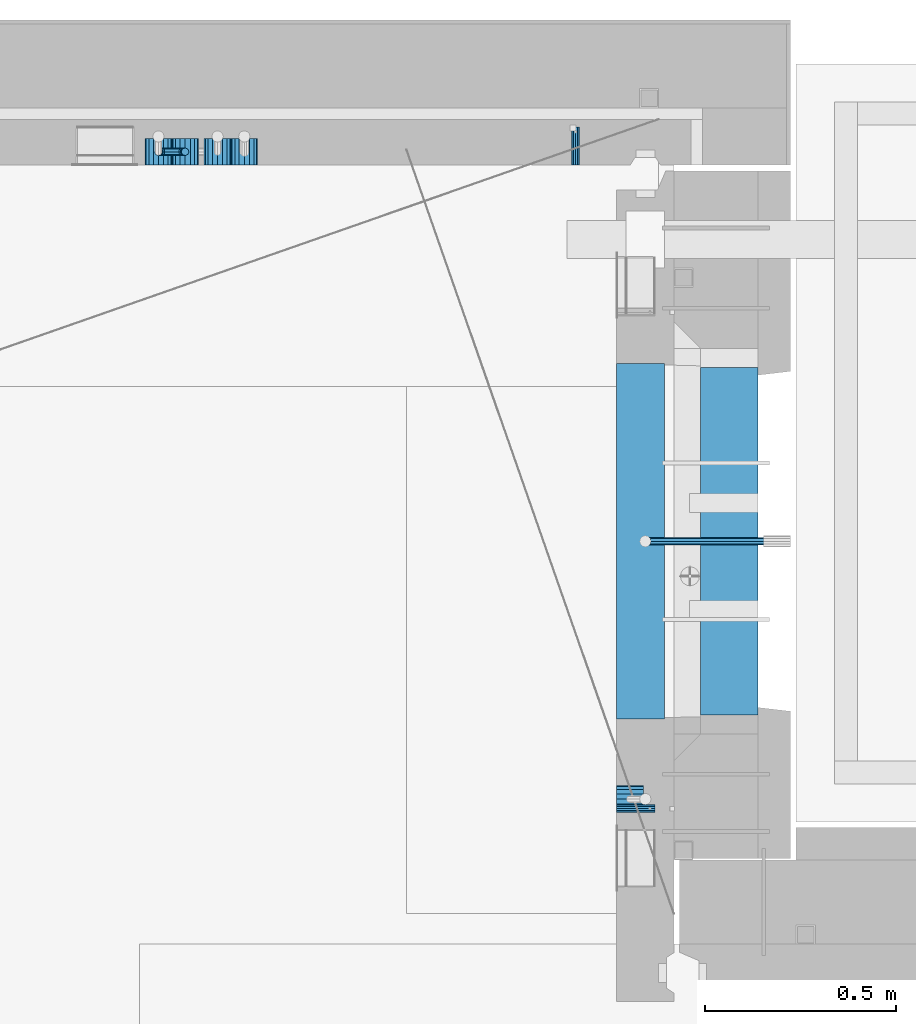
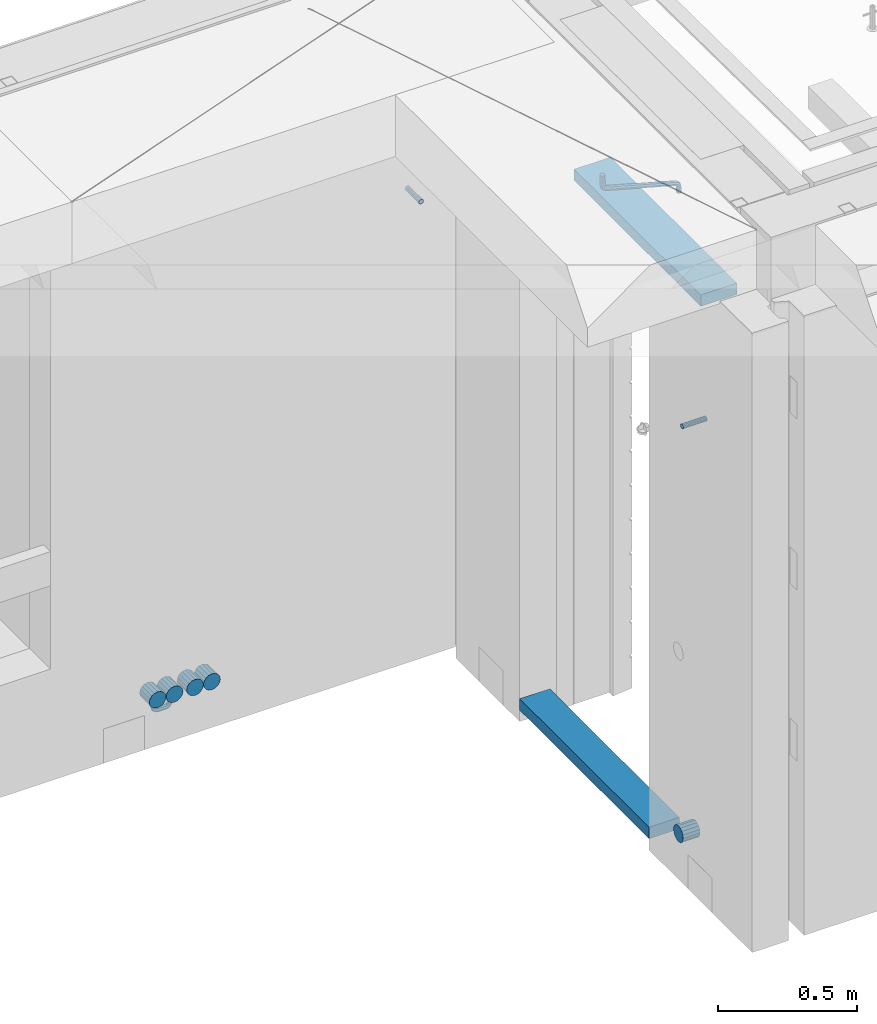
# One storey, part 166 of 352: 11 beams, 4 elements without a shape of their own.
"""IFC2X3 building model written with IfcOpenShell, lengths in millimetres."""

from ifc_helpers import new_model, si_unit, frame, origin_with_axes, place, context, subcontext, project, spatial, faceted_brep, material, type_object, element, aggregate, save


model = new_model("IFC2X3")

# Units and contexts
model_context = context("Model", 3, precision=1e-05, world=origin_with_axes())
body_context = subcontext(model_context, "Body", "Model", "MODEL_VIEW")
ifc_project = project(units=[si_unit("LENGTHUNIT", "METRE", prefix="MILLI"), si_unit("AREAUNIT", "SQUARE_METRE"), si_unit("VOLUMEUNIT", "CUBIC_METRE"), si_unit("MASSUNIT", "GRAM", prefix="KILO"), si_unit("TIMEUNIT", "SECOND"), si_unit("PLANEANGLEUNIT", "RADIAN"), si_unit("SOLIDANGLEUNIT", "STERADIAN"), si_unit("THERMODYNAMICTEMPERATUREUNIT", "DEGREE_CELSIUS"), si_unit("LUMINOUSINTENSITYUNIT", "LUMEN")], contexts=[model_context])

# Site, building, storey
site_placement = place(None, origin_with_axes())
site = spatial("IfcSite", under=ifc_project, at=site_placement, CompositionType="ELEMENT")
building_placement = place(site_placement, origin_with_axes())
building = spatial("IfcBuilding", under=site, at=building_placement, CompositionType="ELEMENT")
storey_placement = place(building_placement, origin_with_axes())
storey = spatial("IfcBuildingStorey", under=building, at=storey_placement, Name="6", CompositionType="ELEMENT", Elevation=0.0)

# Assembly, beam
assembly_1_placement = place(storey_placement, origin_with_axes())
assembly_1 = element("IfcElementAssembly", 1, at=assembly_1_placement, inside=storey, AssemblyPlace="NOTDEFINED", PredefinedType="REINFORCEMENT_UNIT")
ifc_material_1 = material(Name="TIMBER")
beam_type_1 = type_object("IfcBeamType", Name="50X150", PredefinedType="NOTDEFINED")
beam_1_placement = place(assembly_1_placement, frame((31604.9951872276, 21180.0002716511, 99080.0), z_axis=(0.0, 0.0, -1.0), x_axis=(0.0, 1.0, 0.0)))
beam_1 = element("IfcBeam", 2, at=beam_1_placement, type_object=beam_type_1, material=ifc_material_1, ObjectType="50X150", context=body_context, shape_type="Brep", body=[
    faceted_brep([(0.0, 75.0, -25.0), (1.81898940354586e-12, 75.0, 25.0), (909.999618530273, 75.0, 25.0), (909.999618530273, 75.0, -25.0), (1.81898940354586e-12, -75.0000000000009, 25.0), (909.999618530273, -75.0, 25.0), (0.0, -75.0, -25.0), (909.999618530273, -75.0, -25.0)], [[[0, 1, 2, 3]], [[1, 4, 5, 2]], [[4, 6, 7, 5]], [[6, 0, 3, 7]], [[5, 7, 3, 2]], [[6, 4, 1, 0]]]),
])

# Assemblies, beam
assembly_2_placement = place(storey_placement, origin_with_axes())
assembly_2 = element("IfcElementAssembly", 3, at=assembly_2_placement, inside=storey, AssemblyPlace="NOTDEFINED", PredefinedType="REINFORCEMENT_UNIT")
assembly_3_placement = place(assembly_2_placement, origin_with_axes())
assembly_3 = element("IfcElementAssembly", 4, at=assembly_3_placement, Name="Steel Assembly", AssemblyPlace="NOTDEFINED", PredefinedType="RIGID_FRAME")
ifc_material_2 = material(Name="STEEL/Steel_Undefined")
beam_type_2 = type_object("IfcBeamType", PredefinedType="NOTDEFINED")
beam_2_placement = place(assembly_3_placement, frame((31202.4996121022, 22620.0, 98755.0), z_axis=(1.0, 0.0, 0.0), x_axis=(0.0, 1.0, 0.0)))
beam_2 = element("IfcBeam", 5, at=beam_2_placement, type_object=beam_type_2, material=ifc_material_2, Name="M16", context=body_context, shape_type="Brep", body=[
    faceted_brep([(0.0, -8.49999999999272, -1.45519152283669e-11), (0.0, -7.36121593215648, 4.24999999998545), (100.000000000262, -7.36121593215648, 4.24999999998545), (100.000000000262, -8.49999999999272, -1.45519152283669e-11), (0.0, -4.24999999998545, 7.36121593216376), (100.000000000262, -4.24999999998545, 7.36121593216376), (0.0, 1.45519152283669e-11, 8.49999999998545), (100.000000000262, 1.45519152283669e-11, 8.49999999998545), (0.0, 4.25000000001455, 7.36121593216376), (100.000000000262, 4.25000000001455, 7.36121593216376), (0.0, 7.36121593217104, 4.24999999998545), (100.000000000262, 7.36121593217104, 4.24999999998545), (0.0, 8.50000000000728, 0.0), (100.000000000262, 8.50000000000728, 0.0), (0.0, 7.36121593217104, -4.25000000001455), (100.000000000262, 7.36121593217104, -4.25000000001455), (0.0, 4.25000000000728, -7.36121593219286), (100.000000000262, 4.25000000000728, -7.36121593219286), (0.0, 7.27595761418343e-12, -8.5), (100.000000000262, 7.27595761418343e-12, -8.5), (0.0, -4.24999999999272, -7.36121593217831), (100.000000000262, -4.24999999999272, -7.36121593217831), (0.0, -7.36121593215648, -4.25), (100.000000000262, -7.36121593215648, -4.25), (0.0, -10.4999999999927, -1.45519152283669e-11), (0.0, -9.09326673972828, -5.25000000001455), (100.000000000262, -9.09326673972828, -5.25000000001455), (100.000000000262, -10.4999999999927, -1.45519152283669e-11), (0.0, -5.24999999998545, -9.09326673974283), (100.000000000262, -5.24999999998545, -9.09326673974283), (0.0, 7.27595761418343e-12, -10.5), (100.000000000262, 7.27595761418343e-12, -10.5), (0.0, 5.25000000001455, -9.09326673975738), (100.000000000262, 5.25000000001455, -9.09326673975738), (0.0, 9.09326673975011, -5.25000000001455), (100.000000000262, 9.09326673975011, -5.25000000001455), (0.0, 10.5000000000073, -1.45519152283669e-11), (100.000000000262, 10.5000000000073, -1.45519152283669e-11), (0.0, 9.09326673975011, 5.25), (100.000000000262, 9.09326673975011, 5.25), (0.0, 5.25000000000728, 9.09326673972828), (100.000000000262, 5.25000000000728, 9.09326673972828), (0.0, 1.45519152283669e-11, 10.4999999999854), (100.000000000262, 1.45519152283669e-11, 10.4999999999854), (0.0, -5.24999999999272, 9.09326673972828), (100.000000000262, -5.24999999999272, 9.09326673972828), (0.0, -9.09326673972828, 5.24999999998545), (100.000000000262, -9.09326673972828, 5.24999999998545)], [[[0, 1, 2, 3]], [[1, 4, 5, 2]], [[4, 6, 7, 5]], [[6, 8, 9, 7]], [[8, 10, 11, 9]], [[10, 12, 13, 11]], [[12, 14, 15, 13]], [[14, 16, 17, 15]], [[16, 18, 19, 17]], [[18, 20, 21, 19]], [[20, 22, 23, 21]], [[22, 0, 3, 23]], [[24, 25, 26, 27]], [[25, 28, 29, 26]], [[28, 30, 31, 29]], [[30, 32, 33, 31]], [[32, 34, 35, 33]], [[34, 36, 37, 35]], [[36, 38, 39, 37]], [[38, 40, 41, 39]], [[40, 42, 43, 41]], [[42, 44, 45, 43]], [[44, 46, 47, 45]], [[46, 24, 27, 47]], [[29, 31, 33, 35, 37, 39, 41, 43, 45, 47, 27, 26], [5, 7, 9, 11, 13, 15, 17, 19, 21, 23, 3, 2]], [[46, 44, 42, 40, 38, 36, 34, 32, 30, 28, 25, 24], [22, 20, 18, 16, 14, 12, 10, 8, 6, 4, 1, 0]]]),
])
aggregate(assembly_3, [beam_2])

# Assembly, beam
assembly_4_placement = place(assembly_1_placement, origin_with_axes())
assembly_4 = element("IfcElementAssembly", 6, at=assembly_4_placement, Name="Steel Assembly", AssemblyPlace="NOTDEFINED", PredefinedType="RIGID_FRAME")
beam_3_placement = place(assembly_4_placement, frame((31309.9951872276, 20934.9968878339, 98755.0), z_axis=(0.0, -1.0, 0.0), x_axis=(1.0, 0.0, 0.0)))
beam_3 = element("IfcBeam", 7, at=beam_3_placement, type_object=beam_type_2, material=ifc_material_2, Name="M16", context=body_context, shape_type="Brep", body=[
    faceted_brep([(0.0, -8.49999999999272, -1.45519152283669e-11), (0.0, -7.36121593215648, 4.24999999998545), (100.000000000262, -7.36121593215648, 4.24999999998545), (100.000000000262, -8.49999999999272, -1.45519152283669e-11), (0.0, -4.24999999998545, 7.36121593216376), (100.000000000262, -4.24999999998545, 7.36121593216376), (0.0, 1.45519152283669e-11, 8.49999999998545), (100.000000000262, 1.45519152283669e-11, 8.49999999998545), (0.0, 4.25000000001455, 7.36121593216376), (100.000000000262, 4.25000000001455, 7.36121593216376), (0.0, 7.36121593217104, 4.24999999998545), (100.000000000262, 7.36121593217104, 4.24999999998545), (0.0, 8.50000000000728, 0.0), (100.000000000262, 8.50000000000728, 0.0), (0.0, 7.36121593217104, -4.25000000001455), (100.000000000262, 7.36121593217104, -4.25000000001455), (0.0, 4.25000000000728, -7.36121593219286), (100.000000000262, 4.25000000000728, -7.36121593219286), (0.0, 7.27595761418343e-12, -8.5), (100.000000000262, 7.27595761418343e-12, -8.5), (0.0, -4.24999999999272, -7.36121593217831), (100.000000000262, -4.24999999999272, -7.36121593217831), (0.0, -7.36121593215648, -4.25), (100.000000000262, -7.36121593215648, -4.25), (0.0, -10.4999999999927, -1.45519152283669e-11), (0.0, -9.09326673972828, -5.25000000001455), (100.000000000262, -9.09326673972828, -5.25000000001455), (100.000000000262, -10.4999999999927, -1.45519152283669e-11), (0.0, -5.24999999998545, -9.09326673974283), (100.000000000262, -5.24999999998545, -9.09326673974283), (0.0, 7.27595761418343e-12, -10.5), (100.000000000262, 7.27595761418343e-12, -10.5), (0.0, 5.25000000001455, -9.09326673975738), (100.000000000262, 5.25000000001455, -9.09326673975738), (0.0, 9.09326673975011, -5.25000000001455), (100.000000000262, 9.09326673975011, -5.25000000001455), (0.0, 10.5000000000073, -1.45519152283669e-11), (100.000000000262, 10.5000000000073, -1.45519152283669e-11), (0.0, 9.09326673975011, 5.25), (100.000000000262, 9.09326673975011, 5.25), (0.0, 5.25000000000728, 9.09326673972828), (100.000000000262, 5.25000000000728, 9.09326673972828), (0.0, 1.45519152283669e-11, 10.4999999999854), (100.000000000262, 1.45519152283669e-11, 10.4999999999854), (0.0, -5.24999999999272, 9.09326673972828), (100.000000000262, -5.24999999999272, 9.09326673972828), (0.0, -9.09326673972828, 5.24999999998545), (100.000000000262, -9.09326673972828, 5.24999999998545)], [[[0, 1, 2, 3]], [[1, 4, 5, 2]], [[4, 6, 7, 5]], [[6, 8, 9, 7]], [[8, 10, 11, 9]], [[10, 12, 13, 11]], [[12, 14, 15, 13]], [[14, 16, 17, 15]], [[16, 18, 19, 17]], [[18, 20, 21, 19]], [[20, 22, 23, 21]], [[22, 0, 3, 23]], [[24, 25, 26, 27]], [[25, 28, 29, 26]], [[28, 30, 31, 29]], [[30, 32, 33, 31]], [[32, 34, 35, 33]], [[34, 36, 37, 35]], [[36, 38, 39, 37]], [[38, 40, 41, 39]], [[40, 42, 43, 41]], [[42, 44, 45, 43]], [[44, 46, 47, 45]], [[46, 24, 27, 47]], [[29, 31, 33, 35, 37, 39, 41, 43, 45, 47, 27, 26], [5, 7, 9, 11, 13, 15, 17, 19, 21, 23, 3, 2]], [[46, 44, 42, 40, 38, 36, 34, 32, 30, 28, 25, 24], [22, 20, 18, 16, 14, 12, 10, 8, 6, 4, 1, 0]]]),
])
aggregate(assembly_4, [beam_3])

# Beam
ifc_material_3 = material()
beam_type_3 = type_object("IfcBeamType", Name="D20", PredefinedType="NOTDEFINED")
beam_4_placement = place(assembly_2_placement, frame((30110.0, 22655.0000005921, 96920.0), z_axis=(0.000207344999896057, 0.999999978504025, 0.0), x_axis=(0.0, 0.0, -1.0)))
beam_4 = element("IfcBeam", 8, at=beam_4_placement, type_object=beam_type_3, material=ifc_material_3, Name="JM20", ObjectType="D20", context=body_context, shape_type="Brep", body=[
    faceted_brep([(0.0, -10.0, 0.0), (-4.19531716033816e-08, -7.07106781186667, -7.07106781187031), (15.0, -7.07106781186303, -7.07106781186303), (15.0, -10.0, 0.0), (0.0, 0.0, -10.0), (15.0, 0.0, -10.0), (4.196772351861e-08, 7.07106781186303, -7.07106781186667), (15.0, 7.07106781186303, -7.07106781186303), (0.0, 10.0, 0.0), (15.0, 10.0, 0.0), (4.196772351861e-08, 7.07106781185939, 7.07106781185939), (15.0, 7.07106781186303, 7.07106781186303), (0.0, 0.0, 10.0), (15.0, 0.0, 10.0), (-4.19531716033816e-08, -7.07106781187031, 7.07106781185939), (15.0, -7.07106781186303, 7.07106781186303), (26.4805029249983, 7.71638602031089, -4.48664359282702e-05), (25.3600699192612, 5.00995527536361, -7.07100705464109), (22.6542637537787, -1.5230460533603, -9.99968429821456), (19.9481089831243, -8.05567439054357, -7.07049718768394), (18.826834370062, -10.7612046541835, 0.00067619437322719), (19.9472673757409, -8.05477390922533, 7.07163838257111), (22.6530735411652, -1.52177258047232, 10.0003156261519), (25.3592283118487, 5.01085575670004, 7.07112851561396), (34.1416172347817, -0.856916444474336, 7.07197867868672), (36.213203398147, 1.21320358659068, 0.000785173426265828), (29.141402548732, -5.85652387542723, 10.0012144823486), (24.1416172883619, -10.8569164797627, 7.07258597800683), (22.0710678501491, -12.9289320870121, 0.00164402434893418), (24.1426540134416, -10.8588120558743, -7.06954948090424), (29.1428686994623, -5.8592046249214, -9.99878528456611), (34.1426539599051, -0.858812020647747, -7.07015678022435), (40.0100668298401, -9.63902468957167, 7.07343309580028), (42.7163859636639, -8.51949674357456, 0.00228483768296428), (33.4771117462369, -12.3444560058379, 10.0025597629719), (26.9444371984719, -15.0509857193756, 7.07382216348924), (24.2387953379803, -16.1731654308933, 0.00283506249979837), (26.9451144717314, -15.0536374847834, -7.0683131956248), (33.47806955532, -12.3482061684881, -9.99743986281101), (40.0107441031432, -9.64167645503403, -7.06870226332103), (42.0710678126343, -19.9985334195844, 7.07521456002723), (45.0000000007858, -19.9999995702492, 0.00414690004981821), (35.0000000006694, -19.9979261199842, 10.0041466852272), (27.9289321887481, -19.9985334194498, 7.07521455996903), (25.0, -19.9999995700782, 0.00414690009347396), (27.928932188719, -20.0014657206229, -7.06692075997853), (35.0000000006548, -20.0020730201395, -9.99585288517846), (42.0710678125906, -20.001465720783, -7.0669207599276), (27.928932188137, -50.001465075733, -7.06070040962368), (24.9999999998254, -49.9999989249554, 0.010367250208219), (35.0, -50.0020723751913, -9.98963253479451), (42.071067811863, -50.001465075733, -7.06070040962368), (45.0, -49.999998925141, 0.0103672502445988), (42.071067811863, -49.9985327745489, 7.08143491011288), (35.0, -49.9979254750906, 10.010367035291), (27.928932188137, -49.9985327745489, 7.08143491011288), (42.7163859754073, -61.4805016490391, 0.0127476751804352), (40.0104054746334, -60.3611140008325, -7.05855238820368), (33.4775906501454, -57.6557408577646, -9.98804558495613), (26.944775825672, -54.9491531157582, -7.05967453130143), (24.2387953248981, -53.8268331663385, 0.0111607251892565), (26.9447758256429, -54.9462208145851, 7.08246078858792), (33.4775906501163, -57.6515939576748, 10.0119539853549), (40.0104054746189, -60.3581816996521, 7.08358293168567), (34.1421356237697, -69.1406679865104, 7.08540393637668), (36.213203435691, -71.213201904422, 0.014765702006116), (29.1421356236242, -64.1400607945761, 10.0132993365623), (24.1421356235078, -59.1406682015404, 7.0833304863263), (22.0710678116011, -57.071066584791, 0.011833400807518), (24.1421356235223, -59.1436005027172, -7.05880483355577), (29.1421356236242, -64.1442076946769, -9.98670023374871), (34.1421356237552, -69.1436002877017, -7.05673138350539), (25.3596491481148, -75.008937711249, 7.08662069281127), (26.4805029710988, -77.7163843043891, 0.0161141044009128), (22.6536686472245, -68.475515727856, 10.014198271514), (19.9476881463488, -61.943308343376, 7.08391159978055), (18.8268343233794, -59.2387940514018, 0.0122828682870022), (19.9476881463343, -61.94624064456, -7.05822372010152), (22.6536686471809, -68.4796626279458, -9.98580129879701), (25.3596491480712, -75.0118700124258, -7.05551462707081), (15.0000000001164, -77.0696000043099, 7.08704796086386), (15.0000000001746, -79.9999982800764, 0.0165876003811718), (14.9999999999418, -69.9979250449542, 10.0145139355009), (14.9999999997963, -62.9274646845297, 7.08411565970164), (15.0, -59.9999987101801, 0.0124407002949738), (14.9999999997672, -62.9303969856919, -7.05801966018043), (14.9999999998836, -70.0020719450404, -9.98548563481017), (15.0000000000582, -77.0725323054685, -7.05508735901822), (0.0, -62.9303969859466, -7.05801966011495), (0.0, -59.9999987101801, 0.0124407002949738), (0.0, -70.0020719452732, -9.98548563470104), (0.0, -77.0725323056759, -7.0550873589309), (0.0, -79.9999982802619, 0.0165876003884478), (0.0, -77.0696000044954, 7.08704796080565), (0.0, -69.9979250451725, 10.0145139353845), (0.0, -62.9274646847625, 7.0841156596216)], [[[0, 1, 2, 3]], [[1, 4, 5, 2]], [[4, 6, 7, 5]], [[6, 8, 9, 7]], [[8, 10, 11, 9]], [[10, 12, 13, 11]], [[12, 14, 15, 13]], [[14, 0, 3, 15]], [[14, 12, 10, 8, 6, 4, 1, 0]], [[7, 9, 16, 17]], [[5, 7, 17, 18]], [[2, 5, 18, 19]], [[3, 2, 19, 20]], [[15, 3, 20, 21]], [[13, 15, 21, 22]], [[11, 13, 22, 23]], [[9, 11, 23, 16]], [[23, 24, 25, 16]], [[22, 26, 24, 23]], [[21, 27, 26, 22]], [[20, 28, 27, 21]], [[19, 29, 28, 20]], [[18, 30, 29, 19]], [[17, 31, 30, 18]], [[16, 25, 31, 17]], [[24, 32, 33, 25]], [[26, 34, 32, 24]], [[27, 35, 34, 26]], [[28, 36, 35, 27]], [[29, 37, 36, 28]], [[30, 38, 37, 29]], [[31, 39, 38, 30]], [[25, 33, 39, 31]], [[32, 40, 41, 33]], [[34, 42, 40, 32]], [[35, 43, 42, 34]], [[36, 44, 43, 35]], [[37, 45, 44, 36]], [[38, 46, 45, 37]], [[39, 47, 46, 38]], [[33, 41, 47, 39]], [[44, 45, 48, 49]], [[45, 46, 50, 48]], [[46, 47, 51, 50]], [[47, 41, 52, 51]], [[41, 40, 53, 52]], [[40, 42, 54, 53]], [[42, 43, 55, 54]], [[43, 44, 49, 55]], [[51, 52, 56, 57]], [[50, 51, 57, 58]], [[48, 50, 58, 59]], [[49, 48, 59, 60]], [[55, 49, 60, 61]], [[54, 55, 61, 62]], [[53, 54, 62, 63]], [[52, 53, 63, 56]], [[63, 64, 65, 56]], [[62, 66, 64, 63]], [[61, 67, 66, 62]], [[60, 68, 67, 61]], [[59, 69, 68, 60]], [[58, 70, 69, 59]], [[57, 71, 70, 58]], [[56, 65, 71, 57]], [[64, 72, 73, 65]], [[66, 74, 72, 64]], [[67, 75, 74, 66]], [[68, 76, 75, 67]], [[69, 77, 76, 68]], [[70, 78, 77, 69]], [[71, 79, 78, 70]], [[65, 73, 79, 71]], [[72, 80, 81, 73]], [[74, 82, 80, 72]], [[75, 83, 82, 74]], [[76, 84, 83, 75]], [[77, 85, 84, 76]], [[78, 86, 85, 77]], [[79, 87, 86, 78]], [[73, 81, 87, 79]], [[84, 85, 88, 89]], [[85, 86, 90, 88]], [[86, 87, 91, 90]], [[87, 81, 92, 91]], [[81, 80, 93, 92]], [[80, 82, 94, 93]], [[82, 83, 95, 94]], [[83, 84, 89, 95]], [[90, 91, 92, 93, 94, 95, 89, 88]]]),
])

beam_5_placement = place(assembly_1_placement, frame((31702.0651872276, 21635.0000000039, 99220.28), z_axis=(-0.999209485784166, -0.00020572799995638, -0.0397537569914116), x_axis=(-0.0397537569985676, 6.39999925638301e-08, 0.999209506962626)))
beam_5 = element("IfcBeam", 9, at=beam_5_placement, type_object=beam_type_3, material=ifc_material_3, Name="JM20", ObjectType="D20", context=body_context, shape_type="Brep", body=[
    faceted_brep([(0.0, -10.0, 0.0), (-4.19531716033816e-08, -7.07106781186667, -7.07106781187031), (26.3851730625611, -7.07106780271351, -7.07106779974674), (26.3851730660535, -9.99999999077045, 1.18243406177498e-08), (0.0, 0.0, -10.0), (26.3851730589668, 9.14587872102857e-09, -9.99999998788189), (4.196772351861e-08, 7.07106781186303, -7.07106781186667), (26.3851730576571, 7.07106782101255, -7.0710677997472), (0.0, 10.0, 0.0), (26.3851730593888, 10.0000000091495, 1.21176526590716e-08), (4.196772351861e-08, 7.07106781185939, 7.07106781185939), (26.3851730631723, 7.07106782101619, 7.07106782398387), (0.0, 0.0, 10.0), (26.3851730667375, 9.15315467864275e-09, 10.0000000121181), (-4.19531716033816e-08, -7.07106781187031, 7.07106781185939), (26.3851730680617, -7.07106780271351, 7.07106782398296), (38.6387990555377, 0.00053833780111745, -7.38336449283906), (37.4430586178205, -7.07058200552274, -4.70977034770021), (34.5550974405633, -9.99964106806146, 1.74460312923975), (31.6666440137633, -7.07083577596131, 8.19887149183023), (30.4697151806322, 0.000179452214069897, 10.8722118684241), (31.6654556183639, 7.07129979554884, 8.19861772327886), (34.5534167956066, 10.0003588580803, 1.74424424634026), (37.4418702223775, 7.07155356597286, -4.71002411625204), (46.5698109210789, 7.07292605872499, 1.96124086770624), (48.7548734831362, 0.00205940803425619, 0.0100898832683924), (41.2967727296491, 10.0013728005906, 6.67270684289633), (36.0246331664675, 7.07195524891722, 11.3845749391899), (33.8417400848848, 0.000686475628754124, 13.3366967298962), (36.0268026468402, -7.07018017507653, 11.385545745416), (41.2998408382991, -9.99862691692761, 6.67407977023777), (46.5719804015243, -7.06920936526149, 1.96221167398289), (52.1766955363273, 7.07494587836845, 11.77897587077), (54.9687243336812, 0.00429788071051007, 10.8906314292522), (45.4389138642146, 10.0028649622, 13.9256551011317), (38.7022804405424, 7.07291984242329, 16.0731735411446), (35.9130237601494, 0.00143263318750542, 16.9635440140905), (38.7050525575032, -7.06921536447044, 16.0751995724927), (45.4428342298197, -9.99713444846202, 13.9285203429881), (52.1794676532882, -7.06718932852891, 11.7810019021831), (142.166420299589, -7.00909836739083, 294.143799597011), (135.429786872017, -9.93904348683645, 296.291318034092), (144.955676979953, 0.0623888418631395, 293.253429124143), (142.163648182657, 7.13303683951744, 294.141773565681), (135.425866510661, 10.0609559233271, 296.288452795829), (128.689233087061, 7.13101080351771, 298.435971235634), (125.899976406712, 0.0595235942673753, 299.326341708503), (128.692005203993, -7.01112440339057, 298.437997266966), (147.068569920637, 0.0631443010061048, 296.926548661886), (144.897857494318, -7.00812174957537, 298.892215917644), (139.655137467547, -9.93753272500544, 303.636800386314), (134.411524128242, -7.00907940566321, 308.380988833921), (132.238655054738, 0.0617899707685865, 310.345700010335), (134.409367481101, 7.13305602133914, 308.38003275464), (139.652087507944, 10.0624669967765, 303.63544828606), (144.895700847192, 7.13401367743427, 298.891259838389), (149.349355837621, 7.13466950711154, 302.082919188319), (150.512901837996, 0.0636515012993186, 299.394888529177), (146.541460642286, 10.0634815017911, 308.572636332), (143.734043175544, 7.13442914049301, 315.062451673432), (142.571650514263, 0.0633115715718304, 317.750719402909), (143.735196514695, -7.0077064342513, 315.062688743805), (146.543091710148, -9.93651842893087, 308.572971600169), (149.350509176773, -7.0074660676255, 302.083156258706), (154.724909358454, 7.13488656737172, 303.143653317829), (154.670204234542, 0.063819369621342, 300.215230568659), (154.856921558763, 10.0638172729959, 310.213489346082), (154.988909878753, 7.13488360238989, 317.283324591871), (155.043557350815, 0.0638151764978829, 320.211745451903), (154.988852227005, -7.00725202125614, 317.28332270274), (154.856840031658, -9.93618272723688, 310.213486674455), (154.724851706691, -7.00724905626703, 303.143651428684), (199.544700311235, -7.00743165723543, 302.30682413155), (199.676688632229, -9.93636532781238, 309.37665937721), (199.490052838737, 0.0636367686238373, 299.378403271518), (199.544757962984, 7.13470396637786, 302.306826020583), (199.676770164122, 10.0636346720203, 309.376662048705), (199.808758485131, 7.13470100144696, 316.446497294365), (199.863405957614, 0.0636325755804137, 319.374918154397), (199.808700833368, -7.00743462216269, 316.446495405334)], [[[0, 1, 2, 3]], [[1, 4, 5, 2]], [[4, 6, 7, 5]], [[6, 8, 9, 7]], [[8, 10, 11, 9]], [[10, 12, 13, 11]], [[12, 14, 15, 13]], [[14, 0, 3, 15]], [[14, 12, 10, 8, 6, 4, 1, 0]], [[2, 5, 16, 17]], [[3, 2, 17, 18]], [[15, 3, 18, 19]], [[13, 15, 19, 20]], [[11, 13, 20, 21]], [[9, 11, 21, 22]], [[7, 9, 22, 23]], [[5, 7, 23, 16]], [[23, 24, 25, 16]], [[22, 26, 24, 23]], [[21, 27, 26, 22]], [[20, 28, 27, 21]], [[19, 29, 28, 20]], [[18, 30, 29, 19]], [[17, 31, 30, 18]], [[16, 25, 31, 17]], [[24, 32, 33, 25]], [[26, 34, 32, 24]], [[27, 35, 34, 26]], [[28, 36, 35, 27]], [[29, 37, 36, 28]], [[30, 38, 37, 29]], [[31, 39, 38, 30]], [[25, 33, 39, 31]], [[38, 39, 40, 41]], [[39, 33, 42, 40]], [[33, 32, 43, 42]], [[32, 34, 44, 43]], [[34, 35, 45, 44]], [[35, 36, 46, 45]], [[36, 37, 47, 46]], [[37, 38, 41, 47]], [[40, 42, 48, 49]], [[41, 40, 49, 50]], [[47, 41, 50, 51]], [[46, 47, 51, 52]], [[45, 46, 52, 53]], [[44, 45, 53, 54]], [[43, 44, 54, 55]], [[42, 43, 55, 48]], [[55, 56, 57, 48]], [[54, 58, 56, 55]], [[53, 59, 58, 54]], [[52, 60, 59, 53]], [[51, 61, 60, 52]], [[50, 62, 61, 51]], [[49, 63, 62, 50]], [[48, 57, 63, 49]], [[56, 64, 65, 57]], [[58, 66, 64, 56]], [[59, 67, 66, 58]], [[60, 68, 67, 59]], [[61, 69, 68, 60]], [[62, 70, 69, 61]], [[63, 71, 70, 62]], [[57, 65, 71, 63]], [[70, 71, 72, 73]], [[71, 65, 74, 72]], [[65, 64, 75, 74]], [[64, 66, 76, 75]], [[66, 67, 77, 76]], [[67, 68, 78, 77]], [[68, 69, 79, 78]], [[69, 70, 73, 79]], [[74, 75, 76, 77, 78, 79, 73, 72]]]),
])

beam_type_4 = type_object("IfcBeamType", Name="D70", PredefinedType="NOTDEFINED")
beam_6_placement = place(assembly_2_placement, frame((30110.0, 22619.9999977209, 96955.0), z_axis=(0.0, 0.0, 1.0), x_axis=(0.0, 1.0, 0.0)))
beam_6 = element("IfcBeam", 10, at=beam_6_placement, type_object=beam_type_4, material=ifc_material_3, ObjectType="D70", context=body_context, shape_type="Brep", body=[
    faceted_brep([(0.0, -35.0, 0.0), (0.0, -32.3357836378964, -13.3939201327739), (70.0, -32.3357836378964, -13.3939201327739), (70.0, -35.0, 0.0), (0.0, -24.7487373415279, -24.7487373415352), (70.0, -24.7487373415279, -24.7487373415352), (0.0, -13.3939201327776, -32.3357836379), (70.0, -13.3939201327776, -32.3357836379), (0.0, 0.0, -35.0), (70.0, 0.0, -35.0), (0.0, 13.3939201327776, -32.3357836379), (70.0, 13.3939201327776, -32.3357836379), (0.0, 24.7487373415279, -24.7487373415352), (70.0, 24.7487373415279, -24.7487373415352), (0.0, 32.3357836378964, -13.3939201327739), (70.0, 32.3357836378964, -13.3939201327739), (0.0, 35.0, 0.0), (70.0, 35.0, 0.0), (0.0, 32.3357836378964, 13.3939201327739), (70.0, 32.3357836378964, 13.3939201327739), (0.0, 24.7487373415279, 24.7487373415352), (70.0, 24.7487373415279, 24.7487373415352), (0.0, 13.3939201327776, 32.3357836379), (70.0, 13.3939201327776, 32.3357836379), (0.0, 0.0, 35.0), (70.0, 0.0, 35.0), (0.0, -13.3939201327776, 32.3357836379), (70.0, -13.3939201327776, 32.3357836379), (0.0, -24.7487373415279, 24.7487373415352), (70.0, -24.7487373415279, 24.7487373415352), (0.0, -32.3357836378964, 13.3939201327739), (70.0, -32.3357836378964, 13.3939201327739)], [[[0, 1, 2, 3]], [[1, 4, 5, 2]], [[4, 6, 7, 5]], [[6, 8, 9, 7]], [[8, 10, 11, 9]], [[10, 12, 13, 11]], [[12, 14, 15, 13]], [[14, 16, 17, 15]], [[16, 18, 19, 17]], [[18, 20, 21, 19]], [[20, 22, 23, 21]], [[22, 24, 25, 23]], [[24, 26, 27, 25]], [[26, 28, 29, 27]], [[28, 30, 31, 29]], [[30, 0, 3, 31]], [[5, 7, 9, 11, 13, 15, 17, 19, 21, 23, 25, 27, 29, 31, 3, 2]], [[30, 28, 26, 24, 22, 20, 18, 16, 14, 12, 10, 8, 6, 4, 1, 0]]]),
])

beam_7_placement = place(assembly_2_placement, frame((30180.0, 22619.9999977209, 96955.0), z_axis=(0.0, 0.0, 1.0), x_axis=(0.0, 1.0, 0.0)))
beam_7 = element("IfcBeam", 11, at=beam_7_placement, type_object=beam_type_4, material=ifc_material_3, ObjectType="D70", context=body_context, shape_type="Brep", body=[
    faceted_brep([(0.0, -35.0, 0.0), (0.0, -32.3357836378964, -13.3939201327739), (70.0, -32.3357836378964, -13.3939201327739), (70.0, -35.0, 0.0), (0.0, -24.7487373415279, -24.7487373415352), (70.0, -24.7487373415279, -24.7487373415352), (0.0, -13.3939201327776, -32.3357836379), (70.0, -13.3939201327776, -32.3357836379), (0.0, 0.0, -35.0), (70.0, 0.0, -35.0), (0.0, 13.3939201327776, -32.3357836379), (70.0, 13.3939201327776, -32.3357836379), (0.0, 24.7487373415279, -24.7487373415352), (70.0, 24.7487373415279, -24.7487373415352), (0.0, 32.3357836378964, -13.3939201327739), (70.0, 32.3357836378964, -13.3939201327739), (0.0, 35.0, 0.0), (70.0, 35.0, 0.0), (0.0, 32.3357836378964, 13.3939201327739), (70.0, 32.3357836378964, 13.3939201327739), (0.0, 24.7487373415279, 24.7487373415352), (70.0, 24.7487373415279, 24.7487373415352), (0.0, 13.3939201327776, 32.3357836379), (70.0, 13.3939201327776, 32.3357836379), (0.0, 0.0, 35.0), (70.0, 0.0, 35.0), (0.0, -13.3939201327776, 32.3357836379), (70.0, -13.3939201327776, 32.3357836379), (0.0, -24.7487373415279, 24.7487373415352), (70.0, -24.7487373415279, 24.7487373415352), (0.0, -32.3357836378964, 13.3939201327739), (70.0, -32.3357836378964, 13.3939201327739)], [[[0, 1, 2, 3]], [[1, 4, 5, 2]], [[4, 6, 7, 5]], [[6, 8, 9, 7]], [[8, 10, 11, 9]], [[10, 12, 13, 11]], [[12, 14, 15, 13]], [[14, 16, 17, 15]], [[16, 18, 19, 17]], [[18, 20, 21, 19]], [[20, 22, 23, 21]], [[22, 24, 25, 23]], [[24, 26, 27, 25]], [[26, 28, 29, 27]], [[28, 30, 31, 29]], [[30, 0, 3, 31]], [[5, 7, 9, 11, 13, 15, 17, 19, 21, 23, 25, 27, 29, 31, 3, 2]], [[30, 28, 26, 24, 22, 20, 18, 16, 14, 12, 10, 8, 6, 4, 1, 0]]]),
])

beam_8_placement = place(assembly_2_placement, frame((30265.0, 22619.9999977209, 96955.0), z_axis=(0.0, 0.0, 1.0), x_axis=(0.0, 1.0, 0.0)))
beam_8 = element("IfcBeam", 12, at=beam_8_placement, type_object=beam_type_4, material=ifc_material_3, ObjectType="D70", context=body_context, shape_type="Brep", body=[
    faceted_brep([(0.0, -35.0, 0.0), (0.0, -32.3357836378964, -13.3939201327739), (70.0, -32.3357836378964, -13.3939201327739), (70.0, -35.0, 0.0), (0.0, -24.7487373415279, -24.7487373415352), (70.0, -24.7487373415279, -24.7487373415352), (0.0, -13.3939201327776, -32.3357836379), (70.0, -13.3939201327776, -32.3357836379), (0.0, 0.0, -35.0), (70.0, 0.0, -35.0), (0.0, 13.3939201327776, -32.3357836379), (70.0, 13.3939201327776, -32.3357836379), (0.0, 24.7487373415279, -24.7487373415352), (70.0, 24.7487373415279, -24.7487373415352), (0.0, 32.3357836378964, -13.3939201327739), (70.0, 32.3357836378964, -13.3939201327739), (0.0, 35.0, 0.0), (70.0, 35.0, 0.0), (0.0, 32.3357836378964, 13.3939201327739), (70.0, 32.3357836378964, 13.3939201327739), (0.0, 24.7487373415279, 24.7487373415352), (70.0, 24.7487373415279, 24.7487373415352), (0.0, 13.3939201327776, 32.3357836379), (70.0, 13.3939201327776, 32.3357836379), (0.0, 0.0, 35.0), (70.0, 0.0, 35.0), (0.0, -13.3939201327776, 32.3357836379), (70.0, -13.3939201327776, 32.3357836379), (0.0, -24.7487373415279, 24.7487373415352), (70.0, -24.7487373415279, 24.7487373415352), (0.0, -32.3357836378964, 13.3939201327739), (70.0, -32.3357836378964, 13.3939201327739)], [[[0, 1, 2, 3]], [[1, 4, 5, 2]], [[4, 6, 7, 5]], [[6, 8, 9, 7]], [[8, 10, 11, 9]], [[10, 12, 13, 11]], [[12, 14, 15, 13]], [[14, 16, 17, 15]], [[16, 18, 19, 17]], [[18, 20, 21, 19]], [[20, 22, 23, 21]], [[22, 24, 25, 23]], [[24, 26, 27, 25]], [[26, 28, 29, 27]], [[28, 30, 31, 29]], [[30, 0, 3, 31]], [[5, 7, 9, 11, 13, 15, 17, 19, 21, 23, 25, 27, 29, 31, 3, 2]], [[30, 28, 26, 24, 22, 20, 18, 16, 14, 12, 10, 8, 6, 4, 1, 0]]]),
])

beam_9_placement = place(assembly_2_placement, frame((30335.0, 22619.9999977209, 96955.0), z_axis=(0.0, 0.0, 1.0), x_axis=(0.0, 1.0, 0.0)))
beam_9 = element("IfcBeam", 13, at=beam_9_placement, type_object=beam_type_4, material=ifc_material_3, ObjectType="D70", context=body_context, shape_type="Brep", body=[
    faceted_brep([(0.0, -35.0, 0.0), (0.0, -32.3357836378964, -13.3939201327739), (70.0, -32.3357836378964, -13.3939201327739), (70.0, -35.0, 0.0), (0.0, -24.7487373415279, -24.7487373415352), (70.0, -24.7487373415279, -24.7487373415352), (0.0, -13.3939201327776, -32.3357836379), (70.0, -13.3939201327776, -32.3357836379), (0.0, 0.0, -35.0), (70.0, 0.0, -35.0), (0.0, 13.3939201327776, -32.3357836379), (70.0, 13.3939201327776, -32.3357836379), (0.0, 24.7487373415279, -24.7487373415352), (70.0, 24.7487373415279, -24.7487373415352), (0.0, 32.3357836378964, -13.3939201327739), (70.0, 32.3357836378964, -13.3939201327739), (0.0, 35.0, 0.0), (70.0, 35.0, 0.0), (0.0, 32.3357836378964, 13.3939201327739), (70.0, 32.3357836378964, 13.3939201327739), (0.0, 24.7487373415279, 24.7487373415352), (70.0, 24.7487373415279, 24.7487373415352), (0.0, 13.3939201327776, 32.3357836379), (70.0, 13.3939201327776, 32.3357836379), (0.0, 0.0, 35.0), (70.0, 0.0, 35.0), (0.0, -13.3939201327776, 32.3357836379), (70.0, -13.3939201327776, 32.3357836379), (0.0, -24.7487373415279, 24.7487373415352), (70.0, -24.7487373415279, 24.7487373415352), (0.0, -32.3357836378964, 13.3939201327739), (70.0, -32.3357836378964, 13.3939201327739)], [[[0, 1, 2, 3]], [[1, 4, 5, 2]], [[4, 6, 7, 5]], [[6, 8, 9, 7]], [[8, 10, 11, 9]], [[10, 12, 13, 11]], [[12, 14, 15, 13]], [[14, 16, 17, 15]], [[16, 18, 19, 17]], [[18, 20, 21, 19]], [[20, 22, 23, 21]], [[22, 24, 25, 23]], [[24, 26, 27, 25]], [[26, 28, 29, 27]], [[28, 30, 31, 29]], [[30, 0, 3, 31]], [[5, 7, 9, 11, 13, 15, 17, 19, 21, 23, 25, 27, 29, 31, 3, 2]], [[30, 28, 26, 24, 22, 20, 18, 16, 14, 12, 10, 8, 6, 4, 1, 0]]]),
])

aggregate(assembly_2, [beam_4, beam_6, beam_7, beam_8, beam_9, assembly_3])

beam_10_placement = place(assembly_1_placement, frame((31309.9951872298, 20960.0, 96955.0), z_axis=(0.0, 0.0, 1.0), x_axis=(1.0, 0.0, 0.0)))
beam_10 = element("IfcBeam", 14, at=beam_10_placement, type_object=beam_type_4, material=ifc_material_3, ObjectType="D70", context=body_context, shape_type="Brep", body=[
    faceted_brep([(0.0, -35.0, 0.0), (0.0, -32.3357836378964, -13.3939201327739), (70.0, -32.3357836378964, -13.3939201327739), (70.0, -35.0, 0.0), (0.0, -24.7487373415279, -24.7487373415352), (70.0, -24.7487373415279, -24.7487373415352), (0.0, -13.3939201327776, -32.3357836379), (70.0, -13.3939201327776, -32.3357836379), (0.0, 0.0, -35.0), (70.0, 0.0, -35.0), (0.0, 13.3939201327776, -32.3357836379), (70.0, 13.3939201327776, -32.3357836379), (0.0, 24.7487373415279, -24.7487373415352), (70.0, 24.7487373415279, -24.7487373415352), (0.0, 32.3357836378964, -13.3939201327739), (70.0, 32.3357836378964, -13.3939201327739), (0.0, 35.0, 0.0), (70.0, 35.0, 0.0), (0.0, 32.3357836378964, 13.3939201327739), (70.0, 32.3357836378964, 13.3939201327739), (0.0, 24.7487373415279, 24.7487373415352), (70.0, 24.7487373415279, 24.7487373415352), (0.0, 13.3939201327776, 32.3357836379), (70.0, 13.3939201327776, 32.3357836379), (0.0, 0.0, 35.0), (70.0, 0.0, 35.0), (0.0, -13.3939201327776, 32.3357836379), (70.0, -13.3939201327776, 32.3357836379), (0.0, -24.7487373415279, 24.7487373415352), (70.0, -24.7487373415279, 24.7487373415352), (0.0, -32.3357836378964, 13.3939201327739), (70.0, -32.3357836378964, 13.3939201327739)], [[[0, 1, 2, 3]], [[1, 4, 5, 2]], [[4, 6, 7, 5]], [[6, 8, 9, 7]], [[8, 10, 11, 9]], [[10, 12, 13, 11]], [[12, 14, 15, 13]], [[14, 16, 17, 15]], [[16, 18, 19, 17]], [[18, 20, 21, 19]], [[20, 22, 23, 21]], [[22, 24, 25, 23]], [[24, 26, 27, 25]], [[26, 28, 29, 27]], [[28, 30, 31, 29]], [[30, 0, 3, 31]], [[5, 7, 9, 11, 13, 15, 17, 19, 21, 23, 25, 27, 29, 31, 3, 2]], [[30, 28, 26, 24, 22, 20, 18, 16, 14, 12, 10, 8, 6, 4, 1, 0]]]),
])

ifc_material_4 = material(Name="TIMBER/PUU")
beam_type_5 = type_object("IfcBeamType", PredefinedType="NOTDEFINED")
beam_11_placement = place(assembly_1_placement, frame((31372.4951872276, 22100.0000381475, 96830.0), z_axis=(0.0, 0.0, 1.0), x_axis=(0.0, -1.0, 0.0)))
beam_11 = element("IfcBeam", 15, at=beam_11_placement, type_object=beam_type_5, material=ifc_material_4, context=body_context, shape_type="Brep", body=[
    faceted_brep([(0.0, 62.5, -25.0), (0.0, 62.5, 25.0), (930.0, 62.5, 25.0), (930.0, 62.5, -25.0), (0.0, -62.5, 25.0), (930.0, -62.5, 25.0), (0.0, -62.5, -25.0), (930.0, -62.5, -25.0)], [[[0, 1, 2, 3]], [[1, 4, 5, 2]], [[4, 6, 7, 5]], [[6, 0, 3, 7]], [[5, 7, 3, 2]], [[6, 4, 1, 0]]]),
])

aggregate(assembly_1, [beam_10, beam_5, assembly_4, beam_11, beam_1])

save(model, "model.ifc")
